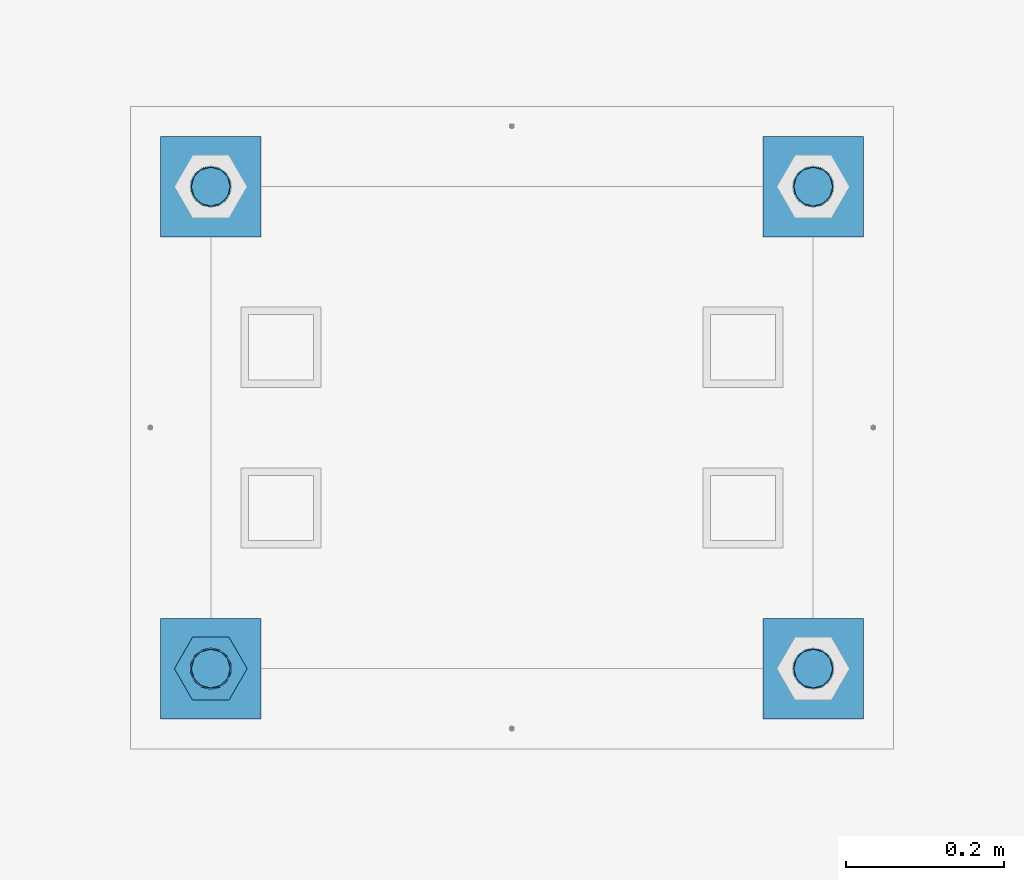
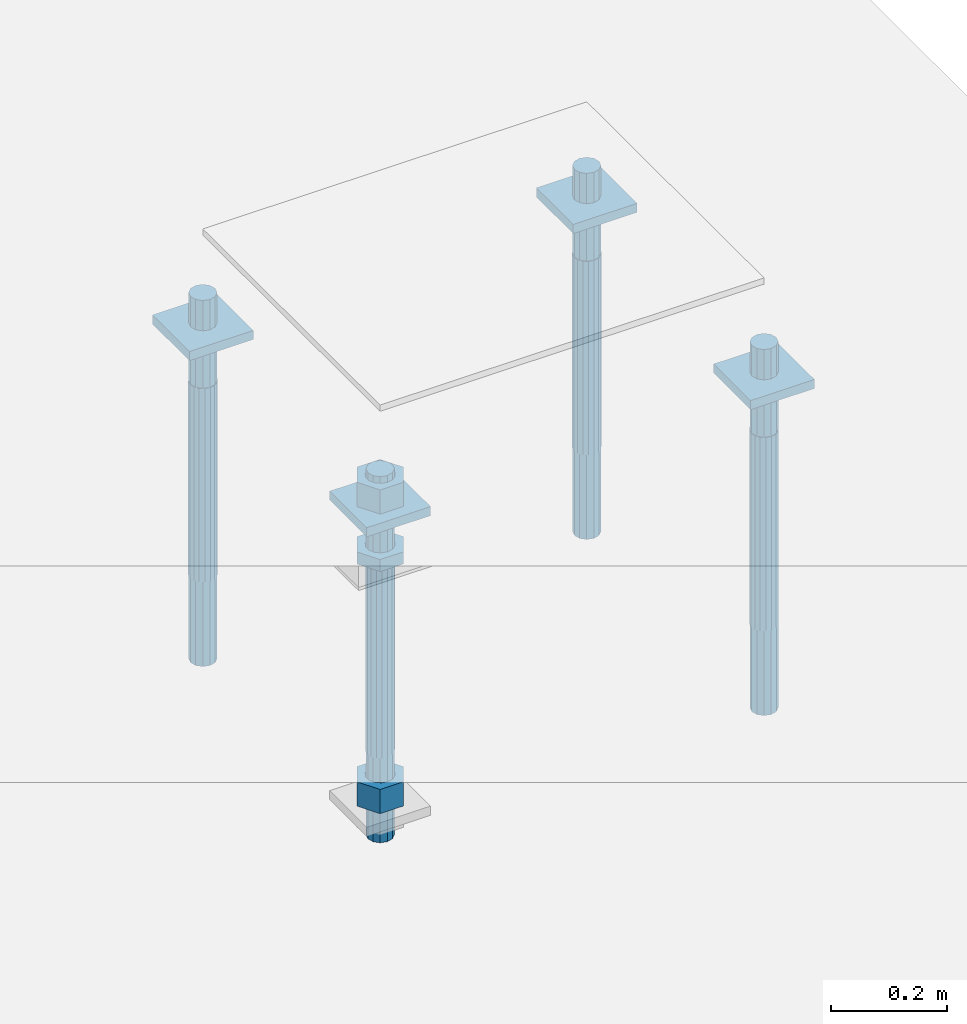
# One storey, part 2738 of 3843: 11 beams, 1 element without a shape of its own.
"""IFC2X3 building model written with IfcOpenShell, lengths in millimetres."""

from ifc_helpers import new_model, si_unit, frame, origin_with_axes, place, context, subcontext, project, spatial, faceted_brep, material, type_object, element, aggregate, save


model = new_model("IFC2X3")

# Units and contexts
model_context = context("Model", 3, precision=1e-05, world=origin_with_axes())
body_context = subcontext(model_context, "Body", "Model", "MODEL_VIEW")
ifc_project = project(units=[si_unit("LENGTHUNIT", "METRE", prefix="MILLI"), si_unit("AREAUNIT", "SQUARE_METRE"), si_unit("VOLUMEUNIT", "CUBIC_METRE"), si_unit("MASSUNIT", "GRAM", prefix="KILO"), si_unit("TIMEUNIT", "SECOND"), si_unit("PLANEANGLEUNIT", "RADIAN"), si_unit("SOLIDANGLEUNIT", "STERADIAN"), si_unit("THERMODYNAMICTEMPERATUREUNIT", "DEGREE_CELSIUS"), si_unit("LUMINOUSINTENSITYUNIT", "LUMEN")], contexts=[model_context])

# Site, building, storey
site_placement = place(None, origin_with_axes())
site = spatial("IfcSite", under=ifc_project, at=site_placement, CompositionType="ELEMENT")
building_placement = place(site_placement, origin_with_axes())
building = spatial("IfcBuilding", under=site, at=building_placement, Name="Undefined", CompositionType="ELEMENT")
storey_placement = place(building_placement, origin_with_axes())
storey = spatial("IfcBuildingStorey", under=building, at=storey_placement, Name="Undefined", CompositionType="ELEMENT", Elevation=0.0)

# Assembly, beams
assembly_placement = place(storey_placement, origin_with_axes())
assembly = element("IfcElementAssembly", 1, at=assembly_placement, inside=storey, Name="TEMPLATE", AssemblyPlace="NOTDEFINED", PredefinedType="RIGID_FRAME")
ifc_material_1 = material(Name="STEEL/A572-50")
beam_type_1 = type_object("IfcBeamType", PredefinedType="NOTDEFINED")
beam_1_placement = place(assembly_placement, frame((118465.6, 35750.5000015259, 29873.575), z_axis=(1.0, 0.0, 0.0), x_axis=(0.0, 1.0, 0.0)))
beam_1 = element("IfcBeam", 2, at=beam_1_placement, type_object=beam_type_1, material=ifc_material_1, Name="WASHER_PLATE", context=body_context, shape_type="Brep", body=[
    faceted_brep([(0.0, 9.52500000000146, -63.5), (0.0, 9.52500000000146, 63.5), (127.0, 9.52500000000146, 63.5), (127.0, 9.52500000000146, -63.5), (0.0, -9.52500000000146, 63.5), (127.0, -9.52500000000146, 63.5), (0.0, -9.52500000000146, -63.5), (127.0, -9.52500000000146, -63.5)], [[[0, 1, 2, 3]], [[1, 4, 5, 2]], [[4, 6, 7, 5]], [[6, 0, 3, 7]], [[5, 7, 3, 2]], [[6, 4, 1, 0]]]),
])
beam_2_placement = place(assembly_placement, frame((119227.6, 35750.5000015259, 29873.575), z_axis=(1.0, 0.0, 0.0), x_axis=(0.0, 1.0, 0.0)))
beam_2 = element("IfcBeam", 3, at=beam_2_placement, type_object=beam_type_1, material=ifc_material_1, Name="WASHER_PLATE", context=body_context, shape_type="Brep", body=[
    faceted_brep([(0.0, 9.52500000000146, -63.5), (0.0, 9.52500000000146, 63.5), (127.0, 9.52500000000146, 63.5), (127.0, 9.52500000000146, -63.5), (0.0, -9.52500000000146, 63.5), (127.0, -9.52500000000146, 63.5), (0.0, -9.52500000000146, -63.5), (127.0, -9.52500000000146, -63.5)], [[[0, 1, 2, 3]], [[1, 4, 5, 2]], [[4, 6, 7, 5]], [[6, 0, 3, 7]], [[5, 7, 3, 2]], [[6, 4, 1, 0]]]),
])
beam_3_placement = place(assembly_placement, frame((118465.6, 36360.1000015259, 29873.575), z_axis=(1.0, 0.0, 0.0), x_axis=(0.0, 1.0, 0.0)))
beam_3 = element("IfcBeam", 4, at=beam_3_placement, type_object=beam_type_1, material=ifc_material_1, Name="WASHER_PLATE", context=body_context, shape_type="Brep", body=[
    faceted_brep([(0.0, 9.52500000000146, -63.5), (0.0, 9.52500000000146, 63.5), (127.0, 9.52500000000146, 63.5), (127.0, 9.52500000000146, -63.5), (0.0, -9.52500000000146, 63.5), (127.0, -9.52500000000146, 63.5), (0.0, -9.52500000000146, -63.5), (127.0, -9.52500000000146, -63.5)], [[[0, 1, 2, 3]], [[1, 4, 5, 2]], [[4, 6, 7, 5]], [[6, 0, 3, 7]], [[5, 7, 3, 2]], [[6, 4, 1, 0]]]),
])
beam_4_placement = place(assembly_placement, frame((119227.6, 36360.1000015259, 29873.575), z_axis=(1.0, 0.0, 0.0), x_axis=(0.0, 1.0, 0.0)))
beam_4 = element("IfcBeam", 5, at=beam_4_placement, type_object=beam_type_1, material=ifc_material_1, Name="WASHER_PLATE", context=body_context, shape_type="Brep", body=[
    faceted_brep([(0.0, 9.52500000000146, -63.5), (0.0, 9.52500000000146, 63.5), (127.0, 9.52500000000146, 63.5), (127.0, 9.52500000000146, -63.5), (0.0, -9.52500000000146, 63.5), (127.0, -9.52500000000146, 63.5), (0.0, -9.52500000000146, -63.5), (127.0, -9.52500000000146, -63.5)], [[[0, 1, 2, 3]], [[1, 4, 5, 2]], [[4, 6, 7, 5]], [[6, 0, 3, 7]], [[5, 7, 3, 2]], [[6, 4, 1, 0]]]),
])
ifc_material_2 = material(Name="STEEL/A36")
beam_type_2 = type_object("IfcBeamType", Name="2_HALF_NUT", PredefinedType="NOTDEFINED")
beam_5_placement = place(assembly_placement, frame((118465.6, 35814.0000015259, 29787.85), z_axis=(0.0, 1.0, 0.0), x_axis=(0.0, 0.0, -1.0)))
beam_5 = element("IfcBeam", 6, at=beam_5_placement, type_object=beam_type_2, material=ifc_material_2, Name="NUT", ObjectType="2_HALF_NUT", context=body_context, shape_type="Brep", body=[
    faceted_brep([(0.0, -46.0369987487793, 0.0), (0.0, -23.0184993743896, -39.869213104248), (25.4000000000015, -23.0184993743896, -39.869213104248), (25.4000000000015, -46.0369987487793, 0.0), (0.0, 23.0184993743896, -39.869213104248), (25.4000000000015, 23.0184993743896, -39.869213104248), (0.0, 46.0369987487793, 0.0), (25.4000000000015, 46.0369987487793, 0.0), (0.0, 23.0184993743896, 39.869213104248), (25.4000000000015, 23.0184993743896, 39.869213104248), (0.0, -23.0184993743896, 39.869213104248), (25.4000000000015, -23.0184993743896, 39.869213104248), (0.0, 0.0, 26.1940002441406), (0.0, 11.3650617044477, 23.5999013092805), (25.4000000000015, 11.3650617044477, 23.5999013092805), (25.4000000000015, 0.0, 26.1940002441406), (0.0, 20.4791109456419, 16.3316083006721), (25.4000000000015, 20.4791109456419, 16.3316083006721), (0.0, 25.5370200498292, 5.82867859874386), (25.4000000000015, 25.5370200498292, 5.82867859874386), (0.0, 25.5370200498292, -5.82867859874386), (25.4000000000015, 25.5370200498292, -5.82867859874386), (0.0, 20.4791109456419, -16.3316083006721), (25.4000000000015, 20.4791109456419, -16.3316083006721), (0.0, 11.3650617044477, -23.5999013092805), (25.4000000000015, 11.3650617044477, -23.5999013092805), (0.0, 0.0, -26.1940002441406), (25.4000000000015, 0.0, -26.1940002441406), (0.0, -11.3650617044477, -23.5999013092805), (25.4000000000015, -11.3650617044477, -23.5999013092805), (0.0, -20.4791109456419, -16.3316083006721), (25.4000000000015, -20.4791109456419, -16.3316083006721), (0.0, -25.5370200498292, -5.82867859874386), (25.4000000000015, -25.5370200498292, -5.82867859874386), (0.0, -25.5370200498292, 5.82867859874386), (25.4000000000015, -25.5370200498292, 5.82867859874386), (0.0, -20.4791109456419, 16.3316083006721), (25.4000000000015, -20.4791109456419, 16.3316083006721), (0.0, -11.3650617044477, 23.5999013092805), (25.4000000000015, -11.3650617044477, 23.5999013092805)], [[[0, 1, 2, 3]], [[1, 4, 5, 2]], [[4, 6, 7, 5]], [[6, 8, 9, 7]], [[8, 10, 11, 9]], [[10, 0, 3, 11]], [[12, 13, 14, 15]], [[13, 16, 17, 14]], [[16, 18, 19, 17]], [[18, 20, 21, 19]], [[20, 22, 23, 21]], [[22, 24, 25, 23]], [[24, 26, 27, 25]], [[26, 28, 29, 27]], [[28, 30, 31, 29]], [[30, 32, 33, 31]], [[32, 34, 35, 33]], [[34, 36, 37, 35]], [[36, 38, 39, 37]], [[38, 12, 15, 39]], [[5, 7, 9, 11, 3, 2], [17, 19, 21, 23, 25, 27, 29, 31, 33, 35, 37, 39, 15, 14]], [[10, 8, 6, 4, 1, 0], [38, 36, 34, 32, 30, 28, 26, 24, 22, 20, 18, 16, 13, 12]]]),
])
beam_type_3 = type_object("IfcBeamType", Name="2_HEAVY_HEX_NUT", PredefinedType="NOTDEFINED")
beam_6_placement = place(assembly_placement, frame((118465.6, 35814.0000015259, 29933.9), z_axis=(0.0, 1.0, 0.0), x_axis=(0.0, 0.0, -1.0)))
beam_6 = element("IfcBeam", 7, at=beam_6_placement, type_object=beam_type_3, material=ifc_material_2, Name="NUT", ObjectType="2_HEAVY_HEX_NUT", context=body_context, shape_type="Brep", body=[
    faceted_brep([(0.0, -46.0369987487793, 0.0), (0.0, -23.0184993743896, -39.869213104248), (50.7999999999993, -23.0184993743896, -39.869213104248), (50.7999999999993, -46.0369987487793, 0.0), (0.0, 23.0184993743896, -39.869213104248), (50.7999999999993, 23.0184993743896, -39.869213104248), (0.0, 46.0369987487793, 0.0), (50.7999999999993, 46.0369987487793, 0.0), (0.0, 23.0184993743896, 39.869213104248), (50.7999999999993, 23.0184993743896, 39.869213104248), (0.0, -23.0184993743896, 39.869213104248), (50.7999999999993, -23.0184993743896, 39.869213104248), (0.0, 0.0, 26.1940002441406), (0.0, 11.3650617044477, 23.5999013092805), (50.7999999999993, 11.3650617044477, 23.5999013092805), (50.7999999999993, 0.0, 26.1940002441406), (0.0, 20.4791109456419, 16.3316083006721), (50.7999999999993, 20.4791109456419, 16.3316083006721), (0.0, 25.5370200498292, 5.82867859874386), (50.7999999999993, 25.5370200498292, 5.82867859874386), (0.0, 25.5370200498292, -5.82867859874386), (50.7999999999993, 25.5370200498292, -5.82867859874386), (0.0, 20.4791109456419, -16.3316083006721), (50.7999999999993, 20.4791109456419, -16.3316083006721), (0.0, 11.3650617044477, -23.5999013092805), (50.7999999999993, 11.3650617044477, -23.5999013092805), (0.0, 0.0, -26.1940002441406), (50.7999999999993, 0.0, -26.1940002441406), (0.0, -11.3650617044477, -23.5999013092805), (50.7999999999993, -11.3650617044477, -23.5999013092805), (0.0, -20.4791109456419, -16.3316083006721), (50.7999999999993, -20.4791109456419, -16.3316083006721), (0.0, -25.5370200498292, -5.82867859874386), (50.7999999999993, -25.5370200498292, -5.82867859874386), (0.0, -25.5370200498292, 5.82867859874386), (50.7999999999993, -25.5370200498292, 5.82867859874386), (0.0, -20.4791109456419, 16.3316083006721), (50.7999999999993, -20.4791109456419, 16.3316083006721), (0.0, -11.3650617044477, 23.5999013092805), (50.7999999999993, -11.3650617044477, 23.5999013092805)], [[[0, 1, 2, 3]], [[1, 4, 5, 2]], [[4, 6, 7, 5]], [[6, 8, 9, 7]], [[8, 10, 11, 9]], [[10, 0, 3, 11]], [[12, 13, 14, 15]], [[13, 16, 17, 14]], [[16, 18, 19, 17]], [[18, 20, 21, 19]], [[20, 22, 23, 21]], [[22, 24, 25, 23]], [[24, 26, 27, 25]], [[26, 28, 29, 27]], [[28, 30, 31, 29]], [[30, 32, 33, 31]], [[32, 34, 35, 33]], [[34, 36, 37, 35]], [[36, 38, 39, 37]], [[38, 12, 15, 39]], [[5, 7, 9, 11, 3, 2], [17, 19, 21, 23, 25, 27, 29, 31, 33, 35, 37, 39, 15, 14]], [[10, 8, 6, 4, 1, 0], [38, 36, 34, 32, 30, 28, 26, 24, 22, 20, 18, 16, 13, 12]]]),
])
beam_7_placement = place(assembly_placement, frame((118465.6, 35814.0000015259, 29305.25), z_axis=(0.0, 1.0, 0.0), x_axis=(0.0, 0.0, -1.0)))
beam_7 = element("IfcBeam", 8, at=beam_7_placement, type_object=beam_type_3, material=ifc_material_2, Name="NUT", ObjectType="2_HEAVY_HEX_NUT", context=body_context, shape_type="Brep", body=[
    faceted_brep([(0.0, -46.0369987487793, 0.0), (0.0, -23.0184993743896, -39.869213104248), (50.7999999999993, -23.0184993743896, -39.869213104248), (50.7999999999993, -46.0369987487793, 0.0), (0.0, 23.0184993743896, -39.869213104248), (50.7999999999993, 23.0184993743896, -39.869213104248), (0.0, 46.0369987487793, 0.0), (50.7999999999993, 46.0369987487793, 0.0), (0.0, 23.0184993743896, 39.869213104248), (50.7999999999993, 23.0184993743896, 39.869213104248), (0.0, -23.0184993743896, 39.869213104248), (50.7999999999993, -23.0184993743896, 39.869213104248), (0.0, 0.0, 26.1940002441406), (0.0, 11.3650617044477, 23.5999013092805), (50.7999999999993, 11.3650617044477, 23.5999013092805), (50.7999999999993, 0.0, 26.1940002441406), (0.0, 20.4791109456419, 16.3316083006721), (50.7999999999993, 20.4791109456419, 16.3316083006721), (0.0, 25.5370200498292, 5.82867859874386), (50.7999999999993, 25.5370200498292, 5.82867859874386), (0.0, 25.5370200498292, -5.82867859874386), (50.7999999999993, 25.5370200498292, -5.82867859874386), (0.0, 20.4791109456419, -16.3316083006721), (50.7999999999993, 20.4791109456419, -16.3316083006721), (0.0, 11.3650617044477, -23.5999013092805), (50.7999999999993, 11.3650617044477, -23.5999013092805), (0.0, 0.0, -26.1940002441406), (50.7999999999993, 0.0, -26.1940002441406), (0.0, -11.3650617044477, -23.5999013092805), (50.7999999999993, -11.3650617044477, -23.5999013092805), (0.0, -20.4791109456419, -16.3316083006721), (50.7999999999993, -20.4791109456419, -16.3316083006721), (0.0, -25.5370200498292, -5.82867859874386), (50.7999999999993, -25.5370200498292, -5.82867859874386), (0.0, -25.5370200498292, 5.82867859874386), (50.7999999999993, -25.5370200498292, 5.82867859874386), (0.0, -20.4791109456419, 16.3316083006721), (50.7999999999993, -20.4791109456419, 16.3316083006721), (0.0, -11.3650617044477, 23.5999013092805), (50.7999999999993, -11.3650617044477, 23.5999013092805)], [[[0, 1, 2, 3]], [[1, 4, 5, 2]], [[4, 6, 7, 5]], [[6, 8, 9, 7]], [[8, 10, 11, 9]], [[10, 0, 3, 11]], [[12, 13, 14, 15]], [[13, 16, 17, 14]], [[16, 18, 19, 17]], [[18, 20, 21, 19]], [[20, 22, 23, 21]], [[22, 24, 25, 23]], [[24, 26, 27, 25]], [[26, 28, 29, 27]], [[28, 30, 31, 29]], [[30, 32, 33, 31]], [[32, 34, 35, 33]], [[34, 36, 37, 35]], [[36, 38, 39, 37]], [[38, 12, 15, 39]], [[5, 7, 9, 11, 3, 2], [17, 19, 21, 23, 25, 27, 29, 31, 33, 35, 37, 39, 15, 14]], [[10, 8, 6, 4, 1, 0], [38, 36, 34, 32, 30, 28, 26, 24, 22, 20, 18, 16, 13, 12]]]),
])
ifc_material_3 = material()
beam_type_4 = type_object("IfcBeamType", PredefinedType="NOTDEFINED")
beam_8_placement = place(assembly_placement, frame((118465.600001526, 36423.6, 29762.45), z_axis=(1.0, 0.0, 0.0), x_axis=(0.0, 0.0, -1.0)))
beam_8 = element("IfcBeam", 9, at=beam_8_placement, type_object=beam_type_4, material=ifc_material_3, Name="ANCHOR_ROD", context=body_context, shape_type="Brep", body=[
    faceted_brep([(0.0, -23.4665401257807, -9.72015918207035), (0.0, -17.9605122421344, -17.9605122421417), (406.399999999998, -17.9605122421344, -17.9605122421417), (406.399999999998, -23.4665401257807, -9.72015918207035), (0.0, -9.72015918207762, -23.466540125788), (406.399999999998, -9.72015918207762, -23.466540125788), (0.0, 0.0, -25.4000000000015), (406.399999999998, 0.0, -25.4000000000015), (0.0, 9.72015918207762, -23.466540125788), (406.399999999998, 9.72015918207762, -23.466540125788), (0.0, 17.9605122421344, -17.9605122421417), (406.399999999998, 17.9605122421344, -17.9605122421417), (0.0, 23.4665401257807, -9.72015918207035), (406.399999999998, 23.4665401257807, -9.72015918207035), (0.0, 25.3999996185303, 0.0), (406.399999999998, 25.3999999999942, 0.0), (0.0, 23.4665401257807, 9.72015918207035), (406.399999999998, 23.4665401257807, 9.72015918207035), (0.0, 17.9605122421344, 17.9605122421417), (406.399999999998, 17.9605122421344, 17.9605122421417), (0.0, 9.72015918207762, 23.466540125788), (406.399999999998, 9.72015918207762, 23.466540125788), (0.0, 0.0, 25.4000000000015), (406.399999999998, 0.0, 25.4000000000015), (0.0, -9.72015918207762, 23.466540125788), (406.399999999998, -9.72015918207762, 23.466540125788), (0.0, -17.9605122421344, 17.9605122421417), (406.399999999998, -17.9605122421344, 17.9605122421417), (0.0, -23.4665401257807, 9.72015918207035), (406.399999999998, -23.4665401257807, 9.72015918207035), (0.0, -25.3999996185303, 0.0), (406.399999999998, -25.3999999999942, 0.0), (584.200000000001, -12.2499999999854, -21.2176223927163), (584.200000000001, 1.45519152283669e-11, -24.5), (584.200000000001, 12.2500000000146, -21.2176223927163), (584.200000000001, 21.2176223927381, -12.25), (584.200000000001, 24.5000000000146, 0.0), (584.200000000001, 21.2176223927381, 12.25), (584.200000000001, 12.2500000000146, 21.2176223927163), (584.200000000001, 1.45519152283669e-11, 24.5), (584.200000000001, -12.2499999999854, 21.2176223927163), (584.200000000001, -21.217622392709, 12.25), (584.200000000001, -24.4999999999854, 0.0), (584.200000000001, -21.217622392709, -12.25), (406.399999999998, -24.4999999999854, 0.0), (406.399999999998, -21.217622392709, -12.25), (406.399999999998, -12.2499999999854, -21.2176223927163), (406.399999999998, 1.45519152283669e-11, -24.5), (406.399999999998, 12.2500000000146, -21.2176223927163), (406.399999999998, 21.2176223927381, -12.25), (406.399999999998, 24.5000000000146, 0.0), (406.399999999998, 21.2176223927381, 12.25), (406.399999999998, 12.2500000000146, 21.2176223927163), (406.399999999998, 1.45519152283669e-11, 24.5), (406.399999999998, -12.2499999999854, 21.2176223927163), (406.399999999998, -21.217622392709, 12.25), (0.0, 12.2500000000146, 21.2176223927163), (0.0, 1.45519152283669e-11, 24.5), (0.0, -12.2499999999854, 21.2176223927163), (0.0, -21.217622392709, 12.25), (0.0, -24.4999999999854, 0.0), (0.0, -21.217622392709, -12.25), (0.0, -12.2499999999854, -21.2176223927163), (0.0, 1.45519152283669e-11, -24.5), (0.0, 12.2500000000146, -21.2176223927163), (0.0, 21.2176223927381, -12.25), (0.0, 24.5000000000146, 0.0), (0.0, 21.2176223927381, 12.25), (-184.150000000001, -21.217622392709, 12.25), (-184.150000000001, -12.2499999999854, 21.2176223927163), (-184.150000000001, 1.45519152283669e-11, 24.5), (-184.150000000001, 12.2500000000146, 21.2176223927163), (-184.150000000001, 21.2176223927381, 12.25), (-184.150000000001, 24.5000000000146, 0.0), (-184.150000000001, 21.2176223927381, -12.25), (-184.150000000001, 12.2500000000146, -21.2176223927163), (-184.150000000001, 1.45519152283669e-11, -24.5), (-184.150000000001, -12.2499999999854, -21.2176223927163), (-184.150000000001, -21.217622392709, -12.25), (-184.150000000001, -24.4999999999854, 0.0)], [[[0, 1, 2, 3]], [[1, 4, 5, 2]], [[4, 6, 7, 5]], [[6, 8, 9, 7]], [[8, 10, 11, 9]], [[10, 12, 13, 11]], [[12, 14, 15, 13]], [[14, 16, 17, 15]], [[16, 18, 19, 17]], [[18, 20, 21, 19]], [[20, 22, 23, 21]], [[22, 24, 25, 23]], [[24, 26, 27, 25]], [[26, 28, 29, 27]], [[28, 30, 31, 29]], [[32, 33, 34, 35, 36, 37, 38, 39, 40, 41, 42, 43]], [[43, 42, 44, 45]], [[32, 43, 45, 46]], [[33, 32, 46, 47]], [[34, 33, 47, 48]], [[35, 34, 48, 49]], [[36, 35, 49, 50]], [[37, 36, 50, 51]], [[38, 37, 51, 52]], [[39, 38, 52, 53]], [[40, 39, 53, 54]], [[41, 40, 54, 55]], [[42, 41, 55, 44]], [[2, 5, 7, 9, 11, 13, 15, 17, 19, 21, 23, 25, 27, 29, 31, 3], [54, 53, 52, 51, 50, 49, 48, 47, 46, 45, 44, 55]], [[30, 0, 3, 31]], [[28, 26, 24, 22, 20, 18, 16, 14, 12, 10, 8, 6, 4, 1, 0, 30], [56, 57, 58, 59, 60, 61, 62, 63, 64, 65, 66, 67]], [[68, 69, 70, 71, 72, 73, 74, 75, 76, 77, 78, 79]], [[71, 70, 57, 56]], [[72, 71, 56, 67]], [[73, 72, 67, 66]], [[74, 73, 66, 65]], [[75, 74, 65, 64]], [[76, 75, 64, 63]], [[77, 76, 63, 62]], [[78, 77, 62, 61]], [[79, 78, 61, 60]], [[68, 79, 60, 59]], [[69, 68, 59, 58]], [[70, 69, 58, 57]]]),
])
beam_9_placement = place(assembly_placement, frame((119227.600001526, 36423.6, 29762.45), z_axis=(1.0, 0.0, 0.0), x_axis=(0.0, 0.0, -1.0)))
beam_9 = element("IfcBeam", 10, at=beam_9_placement, type_object=beam_type_4, material=ifc_material_3, Name="ANCHOR_ROD", context=body_context, shape_type="Brep", body=[
    faceted_brep([(0.0, -23.4665401257807, -9.72015918207035), (0.0, -17.9605122421344, -17.9605122421417), (406.399999999998, -17.9605122421344, -17.9605122421417), (406.399999999998, -23.4665401257807, -9.72015918207035), (0.0, -9.72015918207762, -23.466540125788), (406.399999999998, -9.72015918207762, -23.466540125788), (0.0, 0.0, -25.4000000000015), (406.399999999998, 0.0, -25.4000000000015), (0.0, 9.72015918207762, -23.466540125788), (406.399999999998, 9.72015918207762, -23.466540125788), (0.0, 17.9605122421344, -17.9605122421417), (406.399999999998, 17.9605122421344, -17.9605122421417), (0.0, 23.4665401257807, -9.72015918207035), (406.399999999998, 23.4665401257807, -9.72015918207035), (0.0, 25.3999996185303, 0.0), (406.399999999998, 25.3999999999942, 0.0), (0.0, 23.4665401257807, 9.72015918207035), (406.399999999998, 23.4665401257807, 9.72015918207035), (0.0, 17.9605122421344, 17.9605122421417), (406.399999999998, 17.9605122421344, 17.9605122421417), (0.0, 9.72015918207762, 23.466540125788), (406.399999999998, 9.72015918207762, 23.466540125788), (0.0, 0.0, 25.4000000000015), (406.399999999998, 0.0, 25.4000000000015), (0.0, -9.72015918207762, 23.466540125788), (406.399999999998, -9.72015918207762, 23.466540125788), (0.0, -17.9605122421344, 17.9605122421417), (406.399999999998, -17.9605122421344, 17.9605122421417), (0.0, -23.4665401257807, 9.72015918207035), (406.399999999998, -23.4665401257807, 9.72015918207035), (0.0, -25.3999996185303, 0.0), (406.399999999998, -25.3999999999942, 0.0), (584.200000000001, -12.2499999999854, -21.2176223927163), (584.200000000001, 1.45519152283669e-11, -24.5), (584.200000000001, 12.2500000000146, -21.2176223927163), (584.200000000001, 21.2176223927381, -12.25), (584.200000000001, 24.5000000000146, 0.0), (584.200000000001, 21.2176223927381, 12.25), (584.200000000001, 12.2500000000146, 21.2176223927163), (584.200000000001, 1.45519152283669e-11, 24.5), (584.200000000001, -12.2499999999854, 21.2176223927163), (584.200000000001, -21.217622392709, 12.25), (584.200000000001, -24.4999999999854, 0.0), (584.200000000001, -21.217622392709, -12.25), (406.399999999998, -24.4999999999854, 0.0), (406.399999999998, -21.217622392709, -12.25), (406.399999999998, -12.2499999999854, -21.2176223927163), (406.399999999998, 1.45519152283669e-11, -24.5), (406.399999999998, 12.2500000000146, -21.2176223927163), (406.399999999998, 21.2176223927381, -12.25), (406.399999999998, 24.5000000000146, 0.0), (406.399999999998, 21.2176223927381, 12.25), (406.399999999998, 12.2500000000146, 21.2176223927163), (406.399999999998, 1.45519152283669e-11, 24.5), (406.399999999998, -12.2499999999854, 21.2176223927163), (406.399999999998, -21.217622392709, 12.25), (0.0, 12.2500000000146, 21.2176223927163), (0.0, 1.45519152283669e-11, 24.5), (0.0, -12.2499999999854, 21.2176223927163), (0.0, -21.217622392709, 12.25), (0.0, -24.4999999999854, 0.0), (0.0, -21.217622392709, -12.25), (0.0, -12.2499999999854, -21.2176223927163), (0.0, 1.45519152283669e-11, -24.5), (0.0, 12.2500000000146, -21.2176223927163), (0.0, 21.2176223927381, -12.25), (0.0, 24.5000000000146, 0.0), (0.0, 21.2176223927381, 12.25), (-184.150000000001, -21.217622392709, 12.25), (-184.150000000001, -12.2499999999854, 21.2176223927163), (-184.150000000001, 1.45519152283669e-11, 24.5), (-184.150000000001, 12.2500000000146, 21.2176223927163), (-184.150000000001, 21.2176223927381, 12.25), (-184.150000000001, 24.5000000000146, 0.0), (-184.150000000001, 21.2176223927381, -12.25), (-184.150000000001, 12.2500000000146, -21.2176223927163), (-184.150000000001, 1.45519152283669e-11, -24.5), (-184.150000000001, -12.2499999999854, -21.2176223927163), (-184.150000000001, -21.217622392709, -12.25), (-184.150000000001, -24.4999999999854, 0.0)], [[[0, 1, 2, 3]], [[1, 4, 5, 2]], [[4, 6, 7, 5]], [[6, 8, 9, 7]], [[8, 10, 11, 9]], [[10, 12, 13, 11]], [[12, 14, 15, 13]], [[14, 16, 17, 15]], [[16, 18, 19, 17]], [[18, 20, 21, 19]], [[20, 22, 23, 21]], [[22, 24, 25, 23]], [[24, 26, 27, 25]], [[26, 28, 29, 27]], [[28, 30, 31, 29]], [[32, 33, 34, 35, 36, 37, 38, 39, 40, 41, 42, 43]], [[43, 42, 44, 45]], [[32, 43, 45, 46]], [[33, 32, 46, 47]], [[34, 33, 47, 48]], [[35, 34, 48, 49]], [[36, 35, 49, 50]], [[37, 36, 50, 51]], [[38, 37, 51, 52]], [[39, 38, 52, 53]], [[40, 39, 53, 54]], [[41, 40, 54, 55]], [[42, 41, 55, 44]], [[2, 5, 7, 9, 11, 13, 15, 17, 19, 21, 23, 25, 27, 29, 31, 3], [54, 53, 52, 51, 50, 49, 48, 47, 46, 45, 44, 55]], [[30, 0, 3, 31]], [[28, 26, 24, 22, 20, 18, 16, 14, 12, 10, 8, 6, 4, 1, 0, 30], [56, 57, 58, 59, 60, 61, 62, 63, 64, 65, 66, 67]], [[68, 69, 70, 71, 72, 73, 74, 75, 76, 77, 78, 79]], [[71, 70, 57, 56]], [[72, 71, 56, 67]], [[73, 72, 67, 66]], [[74, 73, 66, 65]], [[75, 74, 65, 64]], [[76, 75, 64, 63]], [[77, 76, 63, 62]], [[78, 77, 62, 61]], [[79, 78, 61, 60]], [[68, 79, 60, 59]], [[69, 68, 59, 58]], [[70, 69, 58, 57]]]),
])
beam_10_placement = place(assembly_placement, frame((118465.600001526, 35814.0, 29762.45), z_axis=(1.0, 0.0, 0.0), x_axis=(0.0, 0.0, -1.0)))
beam_10 = element("IfcBeam", 11, at=beam_10_placement, type_object=beam_type_4, material=ifc_material_3, Name="ANCHOR_ROD", context=body_context, shape_type="Brep", body=[
    faceted_brep([(0.0, -23.4665401257807, -9.72015918207035), (0.0, -17.9605122421344, -17.9605122421417), (406.399999999998, -17.9605122421344, -17.9605122421417), (406.399999999998, -23.4665401257807, -9.72015918207035), (0.0, -9.72015918207762, -23.466540125788), (406.399999999998, -9.72015918207762, -23.466540125788), (0.0, 0.0, -25.4000000000015), (406.399999999998, 0.0, -25.4000000000015), (0.0, 9.72015918207762, -23.466540125788), (406.399999999998, 9.72015918207762, -23.466540125788), (0.0, 17.9605122421344, -17.9605122421417), (406.399999999998, 17.9605122421344, -17.9605122421417), (0.0, 23.4665401257807, -9.72015918207035), (406.399999999998, 23.4665401257807, -9.72015918207035), (0.0, 25.3999996185303, 0.0), (406.399999999998, 25.3999999999942, 0.0), (0.0, 23.4665401257807, 9.72015918207035), (406.399999999998, 23.4665401257807, 9.72015918207035), (0.0, 17.9605122421344, 17.9605122421417), (406.399999999998, 17.9605122421344, 17.9605122421417), (0.0, 9.72015918207762, 23.466540125788), (406.399999999998, 9.72015918207762, 23.466540125788), (0.0, 0.0, 25.4000000000015), (406.399999999998, 0.0, 25.4000000000015), (0.0, -9.72015918207762, 23.466540125788), (406.399999999998, -9.72015918207762, 23.466540125788), (0.0, -17.9605122421344, 17.9605122421417), (406.399999999998, -17.9605122421344, 17.9605122421417), (0.0, -23.4665401257807, 9.72015918207035), (406.399999999998, -23.4665401257807, 9.72015918207035), (0.0, -25.3999996185303, 0.0), (406.399999999998, -25.3999999999942, 0.0), (584.200000000001, -12.2499999999854, -21.2176223927163), (584.200000000001, 1.45519152283669e-11, -24.5), (584.200000000001, 12.2500000000146, -21.2176223927163), (584.200000000001, 21.2176223927381, -12.25), (584.200000000001, 24.5000000000146, 0.0), (584.200000000001, 21.2176223927381, 12.25), (584.200000000001, 12.2500000000146, 21.2176223927163), (584.200000000001, 1.45519152283669e-11, 24.5), (584.200000000001, -12.2499999999854, 21.2176223927163), (584.200000000001, -21.217622392709, 12.25), (584.200000000001, -24.4999999999854, 0.0), (584.200000000001, -21.217622392709, -12.25), (406.399999999998, -24.4999999999854, 0.0), (406.399999999998, -21.217622392709, -12.25), (406.399999999998, -12.2499999999854, -21.2176223927163), (406.399999999998, 1.45519152283669e-11, -24.5), (406.399999999998, 12.2500000000146, -21.2176223927163), (406.399999999998, 21.2176223927381, -12.25), (406.399999999998, 24.5000000000146, 0.0), (406.399999999998, 21.2176223927381, 12.25), (406.399999999998, 12.2500000000146, 21.2176223927163), (406.399999999998, 1.45519152283669e-11, 24.5), (406.399999999998, -12.2499999999854, 21.2176223927163), (406.399999999998, -21.217622392709, 12.25), (0.0, 12.2500000000146, 21.2176223927163), (0.0, 1.45519152283669e-11, 24.5), (0.0, -12.2499999999854, 21.2176223927163), (0.0, -21.217622392709, 12.25), (0.0, -24.4999999999854, 0.0), (0.0, -21.217622392709, -12.25), (0.0, -12.2499999999854, -21.2176223927163), (0.0, 1.45519152283669e-11, -24.5), (0.0, 12.2500000000146, -21.2176223927163), (0.0, 21.2176223927381, -12.25), (0.0, 24.5000000000146, 0.0), (0.0, 21.2176223927381, 12.25), (-184.150000000001, -21.217622392709, 12.25), (-184.150000000001, -12.2499999999854, 21.2176223927163), (-184.150000000001, 1.45519152283669e-11, 24.5), (-184.150000000001, 12.2500000000146, 21.2176223927163), (-184.150000000001, 21.2176223927381, 12.25), (-184.150000000001, 24.5000000000146, 0.0), (-184.150000000001, 21.2176223927381, -12.25), (-184.150000000001, 12.2500000000146, -21.2176223927163), (-184.150000000001, 1.45519152283669e-11, -24.5), (-184.150000000001, -12.2499999999854, -21.2176223927163), (-184.150000000001, -21.217622392709, -12.25), (-184.150000000001, -24.4999999999854, 0.0)], [[[0, 1, 2, 3]], [[1, 4, 5, 2]], [[4, 6, 7, 5]], [[6, 8, 9, 7]], [[8, 10, 11, 9]], [[10, 12, 13, 11]], [[12, 14, 15, 13]], [[14, 16, 17, 15]], [[16, 18, 19, 17]], [[18, 20, 21, 19]], [[20, 22, 23, 21]], [[22, 24, 25, 23]], [[24, 26, 27, 25]], [[26, 28, 29, 27]], [[28, 30, 31, 29]], [[32, 33, 34, 35, 36, 37, 38, 39, 40, 41, 42, 43]], [[43, 42, 44, 45]], [[32, 43, 45, 46]], [[33, 32, 46, 47]], [[34, 33, 47, 48]], [[35, 34, 48, 49]], [[36, 35, 49, 50]], [[37, 36, 50, 51]], [[38, 37, 51, 52]], [[39, 38, 52, 53]], [[40, 39, 53, 54]], [[41, 40, 54, 55]], [[42, 41, 55, 44]], [[2, 5, 7, 9, 11, 13, 15, 17, 19, 21, 23, 25, 27, 29, 31, 3], [54, 53, 52, 51, 50, 49, 48, 47, 46, 45, 44, 55]], [[30, 0, 3, 31]], [[28, 26, 24, 22, 20, 18, 16, 14, 12, 10, 8, 6, 4, 1, 0, 30], [56, 57, 58, 59, 60, 61, 62, 63, 64, 65, 66, 67]], [[68, 69, 70, 71, 72, 73, 74, 75, 76, 77, 78, 79]], [[71, 70, 57, 56]], [[72, 71, 56, 67]], [[73, 72, 67, 66]], [[74, 73, 66, 65]], [[75, 74, 65, 64]], [[76, 75, 64, 63]], [[77, 76, 63, 62]], [[78, 77, 62, 61]], [[79, 78, 61, 60]], [[68, 79, 60, 59]], [[69, 68, 59, 58]], [[70, 69, 58, 57]]]),
])
beam_11_placement = place(assembly_placement, frame((119227.600001526, 35814.0, 29762.45), z_axis=(1.0, 0.0, 0.0), x_axis=(0.0, 0.0, -1.0)))
beam_11 = element("IfcBeam", 12, at=beam_11_placement, type_object=beam_type_4, material=ifc_material_3, Name="ANCHOR_ROD", context=body_context, shape_type="Brep", body=[
    faceted_brep([(0.0, -23.4665401257807, -9.72015918207035), (0.0, -17.9605122421344, -17.9605122421417), (406.399999999998, -17.9605122421344, -17.9605122421417), (406.399999999998, -23.4665401257807, -9.72015918207035), (0.0, -9.72015918207762, -23.466540125788), (406.399999999998, -9.72015918207762, -23.466540125788), (0.0, 0.0, -25.4000000000015), (406.399999999998, 0.0, -25.4000000000015), (0.0, 9.72015918207762, -23.466540125788), (406.399999999998, 9.72015918207762, -23.466540125788), (0.0, 17.9605122421344, -17.9605122421417), (406.399999999998, 17.9605122421344, -17.9605122421417), (0.0, 23.4665401257807, -9.72015918207035), (406.399999999998, 23.4665401257807, -9.72015918207035), (0.0, 25.3999996185303, 0.0), (406.399999999998, 25.3999999999942, 0.0), (0.0, 23.4665401257807, 9.72015918207035), (406.399999999998, 23.4665401257807, 9.72015918207035), (0.0, 17.9605122421344, 17.9605122421417), (406.399999999998, 17.9605122421344, 17.9605122421417), (0.0, 9.72015918207762, 23.466540125788), (406.399999999998, 9.72015918207762, 23.466540125788), (0.0, 0.0, 25.4000000000015), (406.399999999998, 0.0, 25.4000000000015), (0.0, -9.72015918207762, 23.466540125788), (406.399999999998, -9.72015918207762, 23.466540125788), (0.0, -17.9605122421344, 17.9605122421417), (406.399999999998, -17.9605122421344, 17.9605122421417), (0.0, -23.4665401257807, 9.72015918207035), (406.399999999998, -23.4665401257807, 9.72015918207035), (0.0, -25.3999996185303, 0.0), (406.399999999998, -25.3999999999942, 0.0), (584.200000000001, -12.2499999999854, -21.2176223927163), (584.200000000001, 1.45519152283669e-11, -24.5), (584.200000000001, 12.2500000000146, -21.2176223927163), (584.200000000001, 21.2176223927381, -12.25), (584.200000000001, 24.5000000000146, 0.0), (584.200000000001, 21.2176223927381, 12.25), (584.200000000001, 12.2500000000146, 21.2176223927163), (584.200000000001, 1.45519152283669e-11, 24.5), (584.200000000001, -12.2499999999854, 21.2176223927163), (584.200000000001, -21.217622392709, 12.25), (584.200000000001, -24.4999999999854, 0.0), (584.200000000001, -21.217622392709, -12.25), (406.399999999998, -24.4999999999854, 0.0), (406.399999999998, -21.217622392709, -12.25), (406.399999999998, -12.2499999999854, -21.2176223927163), (406.399999999998, 1.45519152283669e-11, -24.5), (406.399999999998, 12.2500000000146, -21.2176223927163), (406.399999999998, 21.2176223927381, -12.25), (406.399999999998, 24.5000000000146, 0.0), (406.399999999998, 21.2176223927381, 12.25), (406.399999999998, 12.2500000000146, 21.2176223927163), (406.399999999998, 1.45519152283669e-11, 24.5), (406.399999999998, -12.2499999999854, 21.2176223927163), (406.399999999998, -21.217622392709, 12.25), (0.0, 12.2500000000146, 21.2176223927163), (0.0, 1.45519152283669e-11, 24.5), (0.0, -12.2499999999854, 21.2176223927163), (0.0, -21.217622392709, 12.25), (0.0, -24.4999999999854, 0.0), (0.0, -21.217622392709, -12.25), (0.0, -12.2499999999854, -21.2176223927163), (0.0, 1.45519152283669e-11, -24.5), (0.0, 12.2500000000146, -21.2176223927163), (0.0, 21.2176223927381, -12.25), (0.0, 24.5000000000146, 0.0), (0.0, 21.2176223927381, 12.25), (-184.150000000001, -21.217622392709, 12.25), (-184.150000000001, -12.2499999999854, 21.2176223927163), (-184.150000000001, 1.45519152283669e-11, 24.5), (-184.150000000001, 12.2500000000146, 21.2176223927163), (-184.150000000001, 21.2176223927381, 12.25), (-184.150000000001, 24.5000000000146, 0.0), (-184.150000000001, 21.2176223927381, -12.25), (-184.150000000001, 12.2500000000146, -21.2176223927163), (-184.150000000001, 1.45519152283669e-11, -24.5), (-184.150000000001, -12.2499999999854, -21.2176223927163), (-184.150000000001, -21.217622392709, -12.25), (-184.150000000001, -24.4999999999854, 0.0)], [[[0, 1, 2, 3]], [[1, 4, 5, 2]], [[4, 6, 7, 5]], [[6, 8, 9, 7]], [[8, 10, 11, 9]], [[10, 12, 13, 11]], [[12, 14, 15, 13]], [[14, 16, 17, 15]], [[16, 18, 19, 17]], [[18, 20, 21, 19]], [[20, 22, 23, 21]], [[22, 24, 25, 23]], [[24, 26, 27, 25]], [[26, 28, 29, 27]], [[28, 30, 31, 29]], [[32, 33, 34, 35, 36, 37, 38, 39, 40, 41, 42, 43]], [[43, 42, 44, 45]], [[32, 43, 45, 46]], [[33, 32, 46, 47]], [[34, 33, 47, 48]], [[35, 34, 48, 49]], [[36, 35, 49, 50]], [[37, 36, 50, 51]], [[38, 37, 51, 52]], [[39, 38, 52, 53]], [[40, 39, 53, 54]], [[41, 40, 54, 55]], [[42, 41, 55, 44]], [[2, 5, 7, 9, 11, 13, 15, 17, 19, 21, 23, 25, 27, 29, 31, 3], [54, 53, 52, 51, 50, 49, 48, 47, 46, 45, 44, 55]], [[30, 0, 3, 31]], [[28, 26, 24, 22, 20, 18, 16, 14, 12, 10, 8, 6, 4, 1, 0, 30], [56, 57, 58, 59, 60, 61, 62, 63, 64, 65, 66, 67]], [[68, 69, 70, 71, 72, 73, 74, 75, 76, 77, 78, 79]], [[71, 70, 57, 56]], [[72, 71, 56, 67]], [[73, 72, 67, 66]], [[74, 73, 66, 65]], [[75, 74, 65, 64]], [[76, 75, 64, 63]], [[77, 76, 63, 62]], [[78, 77, 62, 61]], [[79, 78, 61, 60]], [[68, 79, 60, 59]], [[69, 68, 59, 58]], [[70, 69, 58, 57]]]),
])
aggregate(assembly, [beam_8, beam_9, beam_10, beam_11, beam_1, beam_2, beam_3, beam_4, beam_5, beam_6, beam_7])

save(model, "model.ifc")
